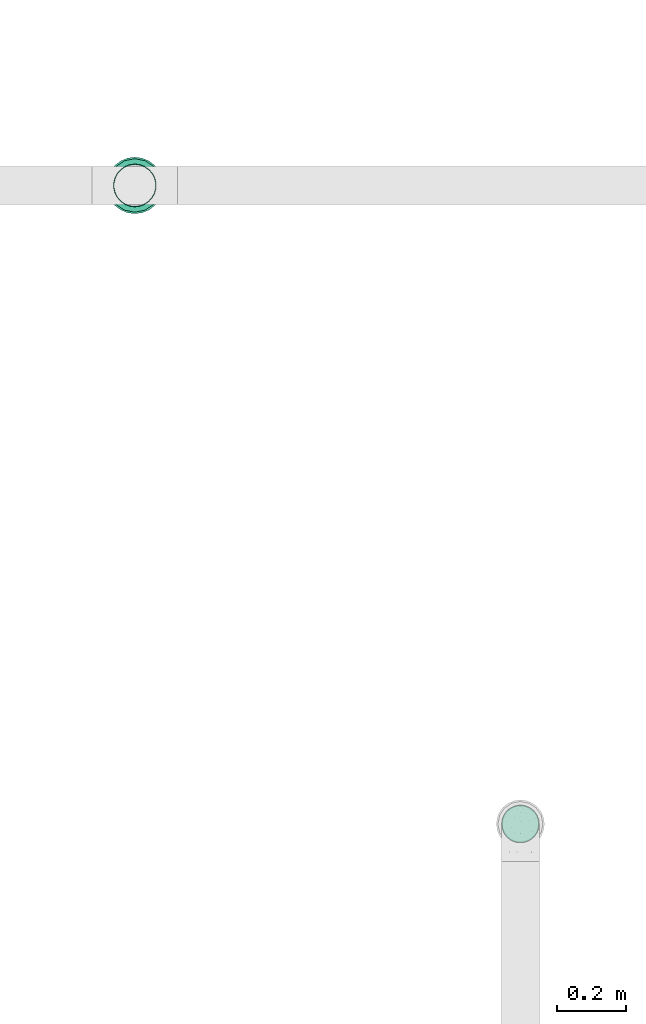
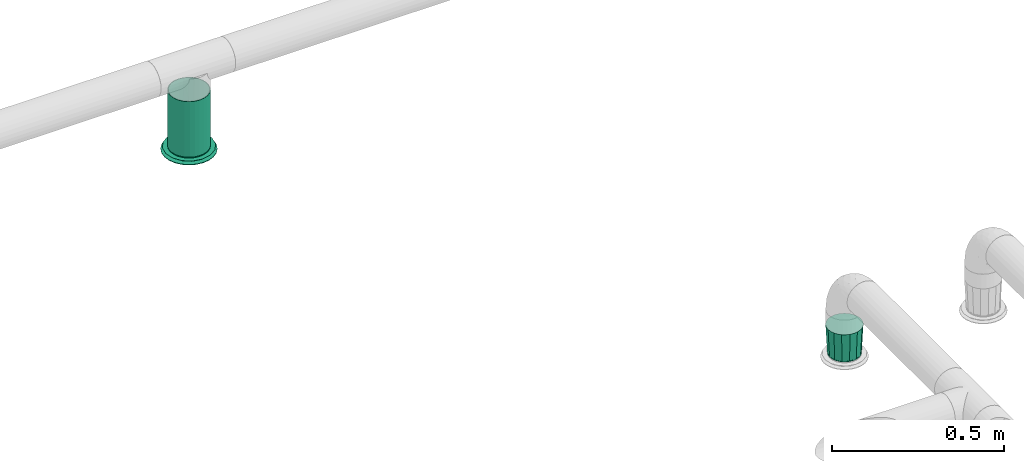
# One storey, part 74 of 115: 1 flow fitting, 1 flow segment, 1 flow terminal.
"""IFC2X3 building model written with IfcOpenShell, lengths in millimetres."""

from ifc_helpers import new_model, entity, si_unit, converted_unit, derived_unit, direction, frame, origin_with_axes, origin_2d_with_axis, place, context, subcontext, project, spatial, hollow_circle, extrude, open_shell, surface_model, source, transform, mapped, material, layer, layer_set, layer_usage, type_object, element, save


model = new_model("IFC2X3")

# Units and contexts
model_context = context("Model", 3, precision=1e-05, world=origin_with_axes(), true_north=direction((0.0, 1.0)))
body_context = subcontext(model_context, "Body", "Model", "MODEL_VIEW")
ifc_project = project(units=[si_unit("AREAUNIT", "SQUARE_METRE"), si_unit("VOLUMEUNIT", "CUBIC_METRE", prefix="DECI"), si_unit("TIMEUNIT", "SECOND"), si_unit("THERMODYNAMICTEMPERATUREUNIT", "DEGREE_CELSIUS"), si_unit("PRESSUREUNIT", "PASCAL"), si_unit("MASSUNIT", "GRAM", prefix="KILO"), si_unit("LENGTHUNIT", "METRE", prefix="MILLI"), si_unit("POWERUNIT", "WATT"), si_unit("ELECTRICCURRENTUNIT", "AMPERE"), si_unit("ELECTRICVOLTAGEUNIT", "VOLT"), derived_unit("VOLUMETRICFLOWRATEUNIT", [(si_unit("VOLUMEUNIT", "CUBIC_METRE", prefix="DECI"), 1), (si_unit("TIMEUNIT", "SECOND"), -1)]), derived_unit("LINEARVELOCITYUNIT", [(si_unit("LENGTHUNIT", "METRE"), 1), (si_unit("TIMEUNIT", "SECOND"), -1)]), derived_unit("MASSDENSITYUNIT", [(si_unit("MASSUNIT", "GRAM", prefix="KILO"), 1), (si_unit("VOLUMEUNIT", "CUBIC_METRE"), -1)]), converted_unit("PLANEANGLEUNIT", "DEGREE", entity("IfcRatioMeasure", 0.01745), si_unit("PLANEANGLEUNIT", "RADIAN"), dimensions=[0, 0, 0, 0, 0, 0, 0])], contexts=[model_context])

# Site, building, storey
site_placement = place(None, origin_with_axes())
site = spatial("IfcSite", under=ifc_project, at=site_placement, CompositionType="ELEMENT")
building_placement = place(site_placement, origin_with_axes())
building = spatial("IfcBuilding", under=site, at=building_placement, Name="mc-building", CompositionType="ELEMENT")
storey_placement = place(building_placement, frame((0.0, 0.0, 2950.0), z_axis=(0.0, 0.0, 1.0), x_axis=(1.0, 0.0, 0.0)))
storey = spatial("IfcBuildingStorey", under=building, at=storey_placement, Name="2. Korrus", CompositionType="ELEMENT", Elevation=2950.0)

# Flow terminal
air_terminal_type = type_object("IfcAirTerminalType", Name="125", PredefinedType="NOTDEFINED")
shared_shape_1 = source(origin_with_axes(), body_context, "Body", "SurfaceModel", [
    surface_model("IfcShellBasedSurfaceModel", [(11.2, 41.25, -71.4471), (11.2, 0.0, -82.5), (11.2, 21.35257, -79.68888), (11.2, 71.4471, -41.25), (11.2, 58.33631, -58.33631), (11.2, 79.68888, -21.35257), (11.2, 82.5, 0.0), (11.2, -79.68888, -21.35257), (11.2, -41.25, -71.4471), (11.2, -21.35257, -79.68888), (11.2, -58.33631, -58.33631), (11.2, -71.4471, -41.25), (11.2, 79.68888, 21.35257), (11.2, 71.4471, 41.25), (11.2, 58.33631, 58.33631), (11.2, 41.25, 71.4471), (11.2, 21.35257, 79.68888), (11.2, -58.33631, 58.33631), (11.2, -21.35257, 79.68888), (11.2, 0.0, 82.5), (11.2, -79.68888, 21.35257), (11.2, -71.4471, 41.25), (11.2, -82.5, 0.0), (11.2, -41.25, 71.4471), (9.2, 21.35257, 79.68888), (9.2, -21.35257, 79.68888), (9.2, 0.0, 82.5), (9.2, 58.33631, 58.33631), (9.2, 41.25, 71.4471), (9.2, 71.4471, 41.25), (9.2, 79.68888, 21.35257), (9.2, -58.33631, 58.33631), (9.2, -41.25, 71.4471), (9.2, -79.68888, 21.35257), (9.2, -71.4471, 41.25), (9.2, -58.33631, -58.33631), (9.2, -82.5, 0.0), (9.2, 79.68888, -21.35257), (9.2, 41.25, -71.4471), (9.2, 71.4471, -41.25), (9.2, -41.25, -71.4471), (9.2, 58.33631, -58.33631), (9.2, 0.0, -82.5), (9.2, 21.35257, -79.68888), (9.2, -71.4471, -41.25), (9.2, -79.68888, -21.35257), (9.2, -21.35257, -79.68888), (9.2, 82.5, 0.0), (9.2, 19.5, 33.77499), (9.2, 0.0, 39.0), (9.2, -19.5, 33.77499), (9.2, -39.0, 0.0), (9.2, 33.77499, 19.5), (9.2, 39.0, 0.0), (9.2, -33.77499, 19.5), (9.2, 0.0, -39.0), (9.2, -33.77499, -19.5), (9.2, -19.5, -33.77499), (9.2, 33.77499, -19.5), (9.2, 19.5, -33.77499), (6.2, 25.24133, 18.3389), (6.2, 31.2, 0.0), (6.2, 9.64133, 29.67296), (6.2, -25.24133, 18.3389), (6.2, -9.64133, 29.67296), (6.2, -31.2, 0.0), (6.2, 25.24133, -18.3389), (6.2, 9.64133, -29.67296), (6.2, -9.64133, -29.67296), (6.2, -25.24133, -18.3389), (9.2, 37.1621, -6.85914), (6.2, 28.22067, -9.16945), (9.2, 35.3242, -13.71829), (6.2, -17.44133, -24.00593), (9.2, -26.6375, -26.6375), (6.2, -28.22067, -9.16945), (9.2, -37.1621, -6.85914), (6.2, 17.44133, -24.00593), (9.2, 9.75, -36.3875), (6.2, 0.0, -29.67296), (9.2, -35.3242, -13.71829), (9.2, 26.6375, -26.6375), (9.2, -9.75, -36.3875), (9.2, -37.1621, 6.85914), (6.2, -28.22067, 9.16945), (9.2, -35.3242, 13.71829), (6.2, 17.44133, 24.00593), (9.2, 26.6375, 26.6375), (6.2, 28.22067, 9.16945), (9.2, 37.1621, 6.85914), (6.2, -17.44133, 24.00593), (9.2, -9.75, 36.3875), (6.2, 0.0, 29.67296), (9.2, 35.3242, 13.71829), (9.2, -26.6375, 26.6375), (9.2, 9.75, 36.3875), (6.2, -26.86438, 64.85634), (6.2, -49.63889, 49.63889), (6.2, -64.85634, 26.86438), (6.2, -70.2, 0.0), (6.2, 64.85634, 26.86438), (6.2, 0.0, 70.2), (6.2, 26.86438, 64.85634), (6.2, 49.63889, 49.63889), (6.2, 70.2, 0.0), (6.2, -64.85634, -26.86438), (6.2, -49.63889, -49.63889), (6.2, -26.86438, -64.85634), (6.2, 26.86438, -64.85634), (6.2, 0.0, -70.2), (6.2, 64.85634, -26.86438), (6.2, 49.63889, -49.63889), (0.0, -29.84931, 72.0626), (0.0, 0.0, 78.0), (0.0, 29.84931, 72.0626), (0.0, 55.15433, 55.15433), (0.0, 78.0, 0.0), (0.0, -55.15433, 55.15433), (0.0, -72.0626, 29.84931), (0.0, -78.0, 0.0), (0.0, 72.0626, 29.84931), (0.0, -72.0626, -29.84931), (0.0, 72.0626, -29.84931), (0.0, 55.15433, -55.15433), (0.0, 29.84931, -72.0626), (0.0, -55.15433, -55.15433), (0.0, -29.84931, -72.0626), (0.0, 0.0, -78.0), (6.2, 66.75025, -17.34304), (0.0, 63.60847, -42.50182), (6.2, 57.24762, -38.25164), (0.0, -14.92465, -75.0313), (6.2, -13.43219, -67.52817), (0.0, 42.50182, -63.60847), (6.2, 38.25164, -57.24762), (0.0, 75.0313, -14.92465), (0.0, 14.92465, -75.0313), (6.2, 13.43219, -67.52817), (0.0, -74.16695, -19.27005), (6.2, -67.52817, -13.43219), (0.0, -42.50182, -63.60847), (6.2, -38.25164, -57.24762), (0.0, -63.60847, -42.50182), (6.2, -57.24762, -38.25164), (6.2, -66.75025, 17.34304), (0.0, -63.60847, 42.50182), (6.2, -57.24762, 38.25164), (0.0, 14.92465, 75.0313), (6.2, 13.43219, 67.52817), (0.0, -42.50182, 63.60847), (6.2, -38.25164, 57.24762), (0.0, -75.0313, 14.92465), (0.0, -14.92465, 75.0313), (6.2, -13.43219, 67.52817), (0.0, 74.16695, 19.27005), (6.2, 67.52817, 13.43219), (0.0, 42.50182, 63.60847), (6.2, 38.25164, 57.24762), (0.0, 63.60847, 42.50182), (6.2, 57.24762, 38.25164), (-3.1, 16.17619, 60.37037), (-3.1, -31.25, 54.12659), (-3.1, 0.0, 62.5), (-3.1, 54.12659, 31.25), (-3.1, 31.25, 54.12659), (-3.1, 44.19417, 44.19417), (-3.1, -54.12659, -31.25), (-3.1, -54.12659, 31.25), (-3.1, -44.19417, 44.19417), (-3.1, -16.17619, 60.37037), (-3.1, -62.5, 0.0), (-3.1, -60.37037, 16.17619), (-3.1, 60.37037, 16.17619), (-3.1, 62.5, 0.0), (-3.1, 60.37037, -16.17619), (-3.1, 54.12659, -31.25), (-3.1, 44.19417, -44.19417), (-3.1, 31.25, -54.12659), (-3.1, 16.17619, -60.37037), (-3.1, -31.25, -54.12659), (-3.1, -44.19417, -44.19417), (-3.1, -60.37037, -16.17619), (-3.1, 0.0, -62.5), (-3.1, -16.17619, -60.37037), (0.0, 31.25, -54.12659), (0.0, -54.12659, -31.25), (0.0, 16.17619, -60.37037), (0.0, 54.12659, -31.25), (0.0, 44.19417, -44.19417), (0.0, 60.37037, -16.17619), (0.0, 62.5, 0.0), (0.0, 54.12659, 31.25), (0.0, 16.17619, 60.37037), (0.0, 0.0, -62.5), (0.0, -31.25, -54.12659), (0.0, -16.17619, -60.37037), (0.0, -44.19417, -44.19417), (0.0, -62.5, 0.0), (0.0, -60.37037, -16.17619), (0.0, 44.19417, 44.19417), (0.0, -54.12659, 31.25), (0.0, 31.25, 54.12659), (0.0, 0.0, 62.5), (0.0, -60.37037, 16.17619), (0.0, -31.25, 54.12659), (0.0, -44.19417, 44.19417), (0.0, -16.17619, 60.37037), (0.0, 60.37037, 16.17619), (-43.1, -14.75269, 55.05777), (-43.1, 0.0, 57.0), (-43.1, 14.75269, 55.05777), (-43.1, 28.5, 49.36345), (-43.1, 40.30508, 40.30508), (-43.1, 49.36345, 28.5), (-43.1, 55.05777, 14.75269), (-43.1, -28.5, 49.36345), (-43.1, -49.36345, 28.5), (-43.1, -40.30508, 40.30508), (-43.1, -57.0, 0.0), (-43.1, -55.05777, 14.75269), (-43.1, -40.30508, -40.30508), (-43.1, 57.0, 0.0), (-43.1, 55.05777, -14.75269), (-43.1, 28.5, -49.36345), (-43.1, 49.36345, -28.5), (-43.1, 14.75269, -55.05777), (-43.1, 40.30508, -40.30508), (-43.1, -49.36345, -28.5), (-43.1, -55.05777, -14.75269), (-43.1, -28.5, -49.36345), (-43.1, 0.0, -57.0), (-43.1, -14.75269, -55.05777), (-3.1, 57.0, 0.0), (-3.1, 14.75269, -55.05777), (-3.1, 28.5, -49.36345), (-3.1, 55.05777, -14.75269), (-3.1, 40.30508, -40.30508), (-3.1, 49.36345, -28.5), (-3.1, 55.05777, 14.75269), (-3.1, -28.5, -49.36345), (-3.1, 0.0, -57.0), (-3.1, -14.75269, -55.05777), (-3.1, -49.36345, -28.5), (-3.1, -57.0, 0.0), (-3.1, -55.05777, -14.75269), (-3.1, -40.30508, -40.30508), (-3.1, -49.36345, 28.5), (-3.1, 49.36345, 28.5), (-3.1, 40.30508, 40.30508), (-3.1, 0.0, 57.0), (-3.1, 28.5, 49.36345), (-3.1, 14.75269, 55.05777), (-3.1, -14.75269, 55.05777), (-3.1, -55.05777, 14.75269), (-3.1, -28.5, 49.36345), (-3.1, -40.30508, 40.30508)], [open_shell([[[0, 1, 2]], [[3, 0, 4]], [[5, 6, 0]], [[5, 0, 3]], [[7, 0, 6]], [[1, 8, 9]], [[1, 0, 8]], [[10, 7, 11]], [[10, 8, 0]], [[7, 10, 0]], [[6, 12, 7]], [[12, 13, 14]], [[12, 14, 15]], [[12, 16, 17]], [[16, 12, 15]], [[18, 16, 19]], [[20, 17, 21]], [[22, 7, 20]], [[17, 18, 23]], [[20, 12, 17]], [[16, 18, 17]], [[20, 7, 12]], [[24, 25, 26]], [[27, 24, 28]], [[27, 29, 30]], [[27, 30, 24]], [[31, 24, 30]], [[25, 31, 32]], [[25, 24, 31]], [[31, 33, 34]], [[31, 30, 33]], [[35, 36, 33]], [[33, 30, 37]], [[33, 37, 35]], [[38, 37, 39]], [[40, 37, 38]], [[38, 39, 41]], [[42, 38, 43]], [[36, 44, 45]], [[35, 44, 36]], [[40, 42, 46]], [[35, 37, 40]], [[38, 42, 40]], [[37, 30, 47]], [[45, 7, 36]], [[44, 11, 45]], [[8, 35, 40]], [[44, 35, 10]], [[9, 40, 46]], [[45, 11, 7]], [[7, 22, 36]], [[9, 8, 40]], [[10, 35, 8]], [[10, 11, 44]], [[1, 9, 46]], [[46, 42, 1]], [[43, 2, 42]], [[38, 0, 43]], [[3, 41, 39]], [[38, 41, 4]], [[5, 39, 37]], [[38, 4, 0]], [[0, 2, 43]], [[6, 5, 37]], [[3, 39, 5]], [[3, 4, 41]], [[47, 6, 37]], [[42, 2, 1]], [[30, 12, 47]], [[29, 13, 30]], [[15, 27, 28]], [[29, 27, 14]], [[16, 28, 24]], [[30, 13, 12]], [[12, 6, 47]], [[16, 15, 28]], [[14, 27, 15]], [[14, 13, 29]], [[19, 16, 24]], [[24, 26, 19]], [[25, 18, 26]], [[32, 23, 25]], [[21, 31, 34]], [[32, 31, 17]], [[20, 34, 33]], [[32, 17, 23]], [[23, 18, 25]], [[36, 22, 20]], [[21, 34, 20]], [[21, 17, 31]], [[33, 36, 20]], [[26, 18, 19]], [[48, 49, 50]], [[50, 51, 52]], [[50, 52, 48]], [[53, 52, 51]], [[50, 54, 51]], [[55, 51, 56]], [[55, 56, 57]], [[58, 55, 59]], [[58, 53, 55]], [[55, 53, 51]], [[60, 61, 62]], [[62, 63, 64]], [[65, 63, 62]], [[62, 61, 65]], [[66, 67, 68]], [[65, 68, 69]], [[65, 61, 68]], [[68, 61, 66]], [[61, 70, 71]], [[58, 71, 72]], [[73, 74, 69]], [[56, 75, 69]], [[76, 51, 65]], [[59, 67, 77]], [[73, 68, 57]], [[74, 73, 57]], [[67, 78, 79]], [[70, 61, 53]], [[65, 75, 76]], [[56, 80, 75]], [[66, 81, 77]], [[82, 57, 68]], [[67, 59, 78]], [[59, 77, 81]], [[81, 66, 58]], [[71, 58, 66]], [[82, 79, 55]], [[78, 55, 79]], [[68, 79, 82]], [[75, 80, 76]], [[56, 69, 74]], [[70, 72, 71]], [[65, 83, 84]], [[54, 84, 85]], [[86, 87, 60]], [[52, 88, 60]], [[89, 53, 61]], [[50, 64, 90]], [[86, 62, 48]], [[87, 86, 48]], [[64, 91, 92]], [[83, 65, 51]], [[61, 88, 89]], [[52, 93, 88]], [[63, 94, 90]], [[95, 48, 62]], [[64, 50, 91]], [[50, 90, 94]], [[94, 63, 54]], [[84, 54, 63]], [[95, 92, 49]], [[91, 49, 92]], [[62, 92, 95]], [[88, 93, 89]], [[52, 60, 87]], [[83, 85, 84]], [[96, 97, 98]], [[98, 99, 96]], [[96, 99, 100]], [[101, 96, 102]], [[100, 103, 102]], [[96, 100, 102]], [[99, 104, 100]], [[105, 106, 107]], [[105, 107, 108]], [[108, 107, 109]], [[110, 104, 111]], [[108, 111, 104]], [[99, 108, 104]], [[108, 99, 105]], [[112, 113, 114]], [[112, 114, 115]], [[116, 112, 115]], [[117, 112, 118]], [[119, 118, 112]], [[119, 112, 116]], [[116, 115, 120]], [[121, 116, 122]], [[123, 124, 122]], [[121, 122, 124]], [[125, 121, 126]], [[126, 121, 124]], [[124, 127, 126]], [[116, 121, 119]], [[110, 122, 128]], [[111, 129, 130]], [[107, 131, 132]], [[108, 133, 134]], [[104, 128, 135]], [[116, 104, 135]], [[111, 134, 123]], [[130, 122, 110]], [[136, 124, 137]], [[128, 122, 135]], [[127, 136, 109]], [[111, 123, 129]], [[119, 138, 139]], [[138, 105, 139]], [[140, 141, 106]], [[124, 108, 137]], [[139, 99, 119]], [[108, 124, 133]], [[106, 125, 140]], [[142, 143, 105]], [[123, 134, 133]], [[131, 127, 132]], [[106, 143, 125]], [[141, 126, 107]], [[126, 141, 140]], [[109, 136, 137]], [[138, 121, 105]], [[122, 130, 129]], [[125, 143, 142]], [[107, 126, 131]], [[127, 109, 132]], [[105, 121, 142]], [[98, 118, 144]], [[97, 145, 146]], [[102, 147, 148]], [[96, 149, 150]], [[99, 144, 151]], [[119, 99, 151]], [[97, 150, 117]], [[146, 118, 98]], [[152, 112, 153]], [[144, 118, 151]], [[113, 152, 101]], [[97, 117, 145]], [[116, 154, 155]], [[154, 100, 155]], [[156, 157, 103]], [[112, 96, 153]], [[155, 104, 116]], [[96, 112, 149]], [[103, 115, 156]], [[158, 159, 100]], [[117, 150, 149]], [[147, 113, 148]], [[103, 159, 115]], [[157, 114, 102]], [[114, 157, 156]], [[101, 152, 153]], [[154, 120, 100]], [[118, 146, 145]], [[115, 159, 158]], [[102, 114, 147]], [[113, 101, 148]], [[100, 120, 158]], [[160, 161, 162]], [[163, 160, 164]], [[161, 160, 163]], [[163, 164, 165]], [[163, 166, 167]], [[161, 167, 168]], [[161, 169, 162]], [[167, 170, 171]], [[167, 161, 163]], [[166, 170, 167]], [[163, 172, 173]], [[173, 174, 175]], [[173, 175, 176]], [[177, 178, 173]], [[177, 173, 176]], [[173, 178, 179]], [[166, 179, 180]], [[181, 170, 166]], [[179, 182, 183]], [[166, 163, 179]], [[182, 179, 178]], [[163, 173, 179]], [[184, 185, 186]], [[187, 184, 188]], [[187, 189, 190]], [[184, 187, 191]], [[192, 185, 184]], [[193, 194, 195]], [[193, 186, 194]], [[194, 185, 196]], [[186, 185, 194]], [[185, 197, 198]], [[190, 191, 187]], [[191, 192, 184]], [[192, 191, 199]], [[192, 200, 185]], [[192, 199, 201]], [[202, 200, 192]], [[197, 200, 203]], [[185, 200, 197]], [[200, 204, 205]], [[202, 204, 200]], [[202, 206, 204]], [[191, 190, 207]], [[172, 207, 173]], [[163, 191, 172]], [[201, 165, 164]], [[163, 165, 199]], [[192, 164, 160]], [[172, 191, 207]], [[207, 190, 173]], [[192, 201, 164]], [[199, 165, 201]], [[199, 191, 163]], [[202, 192, 160]], [[160, 162, 202]], [[169, 206, 162]], [[161, 204, 169]], [[200, 168, 167]], [[161, 168, 205]], [[203, 167, 171]], [[161, 205, 204]], [[204, 206, 169]], [[197, 203, 171]], [[200, 167, 203]], [[200, 205, 168]], [[170, 197, 171]], [[162, 206, 202]], [[181, 198, 170]], [[166, 185, 181]], [[194, 180, 179]], [[166, 180, 196]], [[195, 179, 183]], [[181, 185, 198]], [[198, 197, 170]], [[195, 194, 179]], [[196, 180, 194]], [[196, 185, 166]], [[193, 195, 183]], [[183, 182, 193]], [[178, 186, 182]], [[177, 184, 178]], [[187, 176, 175]], [[177, 176, 188]], [[189, 175, 174]], [[177, 188, 184]], [[184, 186, 178]], [[190, 189, 174]], [[187, 175, 189]], [[187, 188, 176]], [[173, 190, 174]], [[182, 186, 193]], [[208, 209, 210]], [[211, 208, 210]], [[212, 213, 214]], [[212, 214, 211]], [[208, 211, 214]], [[215, 216, 217]], [[216, 215, 208]], [[216, 218, 219]], [[216, 208, 214]], [[216, 220, 218]], [[216, 214, 221]], [[220, 216, 222]], [[223, 222, 224]], [[223, 225, 222]], [[223, 224, 226]], [[220, 222, 225]], [[218, 227, 228]], [[220, 227, 218]], [[229, 230, 231]], [[229, 220, 225]], [[230, 229, 225]], [[216, 221, 222]], [[232, 233, 234]], [[235, 234, 236]], [[235, 232, 234]], [[235, 236, 237]], [[238, 239, 233]], [[240, 239, 241]], [[240, 233, 239]], [[242, 243, 244]], [[245, 239, 246]], [[242, 245, 243]], [[238, 233, 232]], [[238, 247, 248]], [[238, 248, 249]], [[250, 251, 249]], [[250, 249, 248]], [[238, 249, 252]], [[243, 246, 253]], [[245, 246, 243]], [[246, 254, 255]], [[254, 246, 252]], [[238, 252, 246]], [[246, 239, 238]], [[214, 238, 221]], [[213, 247, 214]], [[250, 212, 211]], [[213, 212, 248]], [[251, 211, 210]], [[214, 247, 238]], [[238, 232, 221]], [[251, 250, 211]], [[248, 212, 250]], [[248, 247, 213]], [[249, 251, 210]], [[210, 209, 249]], [[254, 215, 217]], [[246, 216, 219]], [[217, 216, 255]], [[253, 219, 218]], [[208, 254, 252]], [[208, 215, 254]], [[252, 249, 208]], [[217, 255, 254]], [[216, 246, 255]], [[253, 246, 219]], [[218, 243, 253]], [[208, 249, 209]], [[228, 244, 218]], [[227, 242, 228]], [[239, 220, 229]], [[227, 220, 245]], [[241, 229, 231]], [[228, 242, 244]], [[244, 243, 218]], [[241, 239, 229]], [[245, 220, 239]], [[245, 242, 227]], [[240, 241, 231]], [[231, 230, 240]], [[233, 230, 225]], [[234, 225, 223]], [[237, 224, 222]], [[221, 235, 222]], [[225, 234, 233]], [[234, 223, 226]], [[234, 226, 236]], [[226, 224, 236]], [[224, 237, 236]], [[235, 237, 222]], [[221, 232, 235]], [[230, 233, 240]]])]),
])
flow_terminal_placement = place(storey_placement, frame((28929.65714, 6254.72535, 2200.0), z_axis=(1.0, 0.0, 0.0), x_axis=(0.0, 0.0, -1.0)))
element("IfcFlowTerminal", 1, at=flow_terminal_placement, inside=storey, type_object=air_terminal_type, Name="125", context=body_context, shape_type="MappedRepresentation", body=[
    mapped(shared_shape_1, transform((0.0, 0.0, 0.0), scale=1.0)),
])

# Flow fitting
duct_fitting_type = type_object("IfcDuctFittingType", PredefinedType="TRANSITION")
shared_shape_2 = source(origin_with_axes(), body_context, "Body", "SurfaceModel", [
    surface_model("IfcShellBasedSurfaceModel", [(100.0, -55.0, 0.0), (100.0, -12.23865, 53.62104), (100.0, -34.29194, 43.00073), (100.0, 49.55329, 23.86361), (100.0, 34.29194, 43.00073), (100.0, 49.55329, -23.86361), (0.0, -45.04844, -21.69419), (0.0, -50.0, 0.0), (0.0, -45.04844, 21.69419), (0.0, 31.17449, 39.09157), (0.0, 45.04844, 21.69419), (0.0, 50.0, 0.0), (98.0, 47.63139, 27.5), (98.0, 0.0, 55.0), (98.0, 38.89087, 38.89087), (98.0, -38.89087, 38.89087), (98.0, -47.63139, 27.5), (100.0, 12.23865, 53.62104), (100.0, -49.55329, 23.86361), (100.0, 55.0, 0.0), (100.0, 12.23865, -53.62104), (100.0, 34.29194, -43.00073), (100.0, -49.55329, -23.86361), (100.0, -34.29194, -43.00073), (100.0, -12.23865, -53.62104), (0.0, -31.17449, 39.09157), (0.0, -11.12605, 48.7464), (0.0, 11.12605, 48.7464), (0.0, -31.17449, -39.09157), (0.0, 11.12605, -48.7464), (0.0, -11.12605, -48.7464), (0.0, 45.04844, -21.69419), (0.0, 31.17449, -39.09157), (0.0, 47.52422, -10.84709), (0.0, 38.11147, -30.39288), (100.0, 41.92261, -33.43217), (100.0, -41.92261, -33.43217), (0.0, -38.11147, -30.39288), (100.0, 23.2653, -48.31088), (0.0, 21.15027, -43.91899), (100.0, 52.32388, -11.72483), (0.0, 0.0, -48.7464), (100.0, 0.0, -53.62104), (0.0, -21.15027, -43.91899), (100.0, -23.2653, -48.31088), (0.0, -47.52422, -10.84709), (100.0, -52.32388, -11.72483), (0.0, -47.52422, 10.84709), (0.0, -38.11147, 30.39288), (100.0, -41.92261, 33.43217), (100.0, 41.92261, 33.43217), (0.0, 38.11147, 30.39288), (100.0, -23.2653, 48.31088), (0.0, -21.15027, 43.91899), (100.0, -52.32388, 11.72483), (0.0, 0.0, 48.7464), (100.0, 0.0, 53.62104), (0.0, 21.15027, 43.91899), (100.0, 23.2653, 48.31088), (0.0, 47.52422, 10.84709), (100.0, 52.32388, 11.72483), (100.0, -14.23505, -53.12592), (100.0, 0.0, -55.0), (100.0, -27.5, -47.63139), (100.0, 27.5, -47.63139), (100.0, -38.89087, -38.89087), (100.0, -53.12592, -14.23505), (100.0, -47.63139, -27.5), (100.0, -47.63139, 27.5), (100.0, 14.23505, -53.12592), (100.0, 38.89087, -38.89087), (100.0, 47.63139, -27.5), (100.0, 47.63139, 27.5), (100.0, 53.12592, -14.23505), (100.0, -53.12592, 14.23505), (100.0, -38.89087, 38.89087), (100.0, -27.5, 47.63139), (100.0, 0.0, 55.0), (100.0, -14.23505, 53.12592), (100.0, 53.12592, 14.23505), (100.0, 38.89087, 38.89087), (100.0, 27.5, 47.63139), (100.0, 14.23505, 53.12592), (98.0, -27.5, 47.63139), (98.0, -14.23505, 53.12592), (98.0, -53.12592, -14.23505), (98.0, 14.23505, 53.12592), (98.0, 27.5, 47.63139), (98.0, 53.12592, 14.23505), (98.0, 55.0, 0.0), (98.0, -47.63139, -27.5), (98.0, -53.12592, 14.23505), (98.0, 27.5, -47.63139), (98.0, -27.5, -47.63139), (98.0, -38.89087, -38.89087), (98.0, 0.0, -55.0), (98.0, -14.23505, -53.12592), (98.0, 38.89087, -38.89087), (98.0, 47.63139, -27.5), (98.0, 53.12592, -14.23505), (98.0, 14.23505, -53.12592), (98.0, -55.0, 0.0), (0.0, 0.0, 50.0), (0.0, 35.35534, 35.35534), (0.0, -12.94095, 48.29629), (0.0, -25.0, 43.30127), (0.0, -35.35534, 35.35534), (0.0, -48.29629, 12.94095), (0.0, -43.30127, 25.0), (0.0, 25.0, 43.30127), (0.0, 12.94095, 48.29629), (0.0, 43.30127, 25.0), (0.0, 48.29629, 12.94095), (0.0, 25.0, -43.30127), (0.0, 48.29629, -12.94095), (0.0, -48.29629, -12.94095), (0.0, -43.30127, -25.0), (0.0, -12.94095, -48.29629), (0.0, -25.0, -43.30127), (0.0, -35.35534, -35.35534), (0.0, 43.30127, -25.0), (0.0, 35.35534, -35.35534), (0.0, 12.94095, -48.29629), (0.0, 0.0, -50.0), (2.0, -35.35534, -35.35534), (2.0, -25.0, -43.30127), (2.0, -12.94095, -48.29629), (2.0, -43.30127, -25.0), (2.0, 0.0, -50.0), (2.0, -48.29629, -12.94095), (2.0, -50.0, 0.0), (2.0, 12.94095, -48.29629), (2.0, 25.0, -43.30127), (2.0, 43.30127, -25.0), (2.0, 48.29629, -12.94095), (2.0, 35.35534, -35.35534), (2.0, -48.29629, 12.94095), (2.0, -35.35534, 35.35534), (2.0, -43.30127, 25.0), (2.0, 35.35534, 35.35534), (2.0, -12.94095, 48.29629), (2.0, -25.0, 43.30127), (2.0, 0.0, 50.0), (2.0, 43.30127, 25.0), (2.0, 48.29629, 12.94095), (2.0, 50.0, 0.0), (2.0, 25.0, 43.30127), (2.0, 12.94095, 48.29629)], [open_shell([[[0, 1, 2]], [[3, 4, 5]], [[6, 7, 8]], [[9, 10, 11]], [[12, 13, 14]], [[15, 13, 16]], [[0, 4, 17]], [[2, 18, 0]], [[1, 0, 17]], [[3, 5, 19]], [[20, 21, 5]], [[22, 20, 5]], [[22, 5, 0]], [[22, 23, 24]], [[22, 24, 20]], [[4, 0, 5]], [[8, 25, 6]], [[6, 25, 26]], [[6, 26, 27]], [[11, 27, 9]], [[28, 6, 29]], [[30, 28, 29]], [[31, 6, 11]], [[31, 32, 29]], [[31, 29, 6]], [[27, 11, 6]], [[31, 33, 5]], [[34, 35, 32]], [[36, 22, 6]], [[36, 37, 23]], [[38, 29, 39]], [[33, 40, 5]], [[33, 11, 40]], [[19, 40, 11]], [[32, 21, 39]], [[32, 35, 21]], [[34, 31, 35]], [[30, 41, 42]], [[28, 43, 44]], [[42, 41, 20]], [[7, 45, 46]], [[38, 39, 21]], [[46, 0, 7]], [[6, 37, 36]], [[38, 20, 29]], [[43, 30, 24]], [[42, 24, 30]], [[28, 23, 37]], [[6, 22, 45]], [[35, 31, 5]], [[44, 43, 24]], [[20, 41, 29]], [[46, 45, 22]], [[44, 23, 28]], [[8, 47, 18]], [[48, 49, 25]], [[50, 3, 10]], [[50, 51, 4]], [[52, 26, 53]], [[47, 54, 18]], [[47, 7, 54]], [[0, 54, 7]], [[25, 2, 53]], [[25, 49, 2]], [[48, 8, 49]], [[27, 55, 56]], [[9, 57, 58]], [[56, 55, 1]], [[11, 59, 60]], [[52, 53, 2]], [[60, 19, 11]], [[10, 51, 50]], [[52, 1, 26]], [[57, 27, 17]], [[56, 17, 27]], [[9, 4, 51]], [[10, 3, 59]], [[49, 8, 18]], [[58, 57, 17]], [[1, 55, 26]], [[60, 59, 3]], [[58, 4, 9]], [[61, 62, 63]], [[63, 64, 65]], [[66, 67, 68]], [[65, 64, 67]], [[67, 64, 68]], [[69, 64, 62]], [[64, 63, 62]], [[70, 71, 64]], [[72, 64, 71]], [[71, 73, 19]], [[74, 0, 66]], [[72, 68, 64]], [[75, 68, 76]], [[77, 78, 76]], [[72, 76, 68]], [[76, 72, 77]], [[79, 72, 19]], [[19, 72, 71]], [[80, 81, 77]], [[77, 72, 80]], [[82, 77, 81]], [[74, 66, 68]], [[83, 84, 13]], [[15, 83, 13]], [[12, 16, 13]], [[16, 12, 85]], [[86, 87, 13]], [[87, 14, 13]], [[88, 89, 12]], [[89, 90, 12]], [[91, 16, 85]], [[90, 85, 12]], [[89, 92, 90]], [[93, 94, 95]], [[95, 94, 90]], [[96, 93, 95]], [[97, 92, 98]], [[98, 89, 99]], [[100, 95, 92]], [[92, 89, 98]], [[90, 92, 95]], [[101, 91, 85]], [[89, 73, 99]], [[99, 71, 98]], [[92, 97, 64]], [[70, 97, 98]], [[100, 92, 69]], [[73, 71, 99]], [[89, 19, 73]], [[92, 64, 69]], [[64, 97, 70]], [[98, 71, 70]], [[100, 69, 62]], [[62, 95, 100]], [[95, 61, 96]], [[96, 63, 93]], [[90, 94, 67]], [[65, 94, 93]], [[85, 90, 66]], [[63, 65, 93]], [[96, 61, 63]], [[85, 66, 0]], [[66, 90, 67]], [[94, 65, 67]], [[85, 0, 101]], [[62, 61, 95]], [[101, 74, 91]], [[91, 68, 16]], [[83, 15, 76]], [[75, 15, 16]], [[84, 83, 78]], [[74, 68, 91]], [[101, 0, 74]], [[83, 76, 78]], [[76, 15, 75]], [[16, 68, 75]], [[84, 78, 77]], [[77, 13, 84]], [[13, 82, 86]], [[86, 81, 87]], [[12, 14, 72]], [[80, 14, 87]], [[88, 12, 79]], [[81, 80, 87]], [[86, 82, 81]], [[88, 79, 19]], [[79, 12, 72]], [[14, 80, 72]], [[88, 19, 89]], [[77, 82, 13]], [[102, 103, 104]], [[105, 104, 106]], [[107, 108, 106]], [[103, 106, 104]], [[106, 103, 107]], [[109, 103, 110]], [[103, 102, 110]], [[111, 112, 103]], [[113, 103, 112]], [[112, 11, 114]], [[107, 103, 113]], [[113, 115, 107]], [[116, 115, 117]], [[117, 118, 119]], [[116, 117, 119]], [[117, 115, 113]], [[120, 121, 114]], [[113, 114, 121]], [[113, 122, 117]], [[113, 112, 114]], [[117, 122, 123]], [[7, 107, 115]], [[124, 125, 126]], [[127, 124, 126]], [[128, 129, 126]], [[127, 126, 129]], [[130, 129, 128]], [[131, 132, 128]], [[132, 130, 128]], [[133, 134, 135]], [[132, 135, 134]], [[132, 134, 130]], [[134, 136, 130]], [[137, 138, 136]], [[137, 136, 139]], [[140, 137, 139]], [[141, 137, 140]], [[142, 140, 139]], [[143, 139, 144]], [[144, 134, 145]], [[146, 147, 139]], [[139, 136, 144]], [[139, 147, 142]], [[136, 134, 144]], [[11, 134, 114]], [[114, 133, 120]], [[113, 121, 132]], [[135, 121, 120]], [[122, 113, 131]], [[134, 133, 114]], [[11, 145, 134]], [[113, 132, 131]], [[132, 121, 135]], [[120, 133, 135]], [[122, 131, 128]], [[128, 123, 122]], [[123, 126, 117]], [[117, 125, 118]], [[116, 119, 127]], [[124, 119, 118]], [[115, 116, 129]], [[125, 124, 118]], [[117, 126, 125]], [[115, 129, 130]], [[129, 116, 127]], [[119, 124, 127]], [[115, 130, 7]], [[128, 126, 123]], [[7, 136, 107]], [[107, 138, 108]], [[105, 106, 141]], [[137, 106, 108]], [[104, 105, 140]], [[136, 138, 107]], [[7, 130, 136]], [[105, 141, 140]], [[141, 106, 137]], [[108, 138, 137]], [[104, 140, 142]], [[142, 102, 104]], [[102, 147, 110]], [[110, 146, 109]], [[111, 103, 143]], [[139, 103, 109]], [[112, 111, 144]], [[146, 139, 109]], [[110, 147, 146]], [[112, 144, 145]], [[144, 111, 143]], [[103, 139, 143]], [[112, 145, 11]], [[142, 147, 102]]])]),
])
flow_fitting_placement = place(storey_placement, frame((30053.28275, 4393.85998, 2203.1), z_axis=(0.0, -1.0, 0.0), x_axis=(0.0, 0.0, 1.0)))
element("IfcFlowFitting", 2, at=flow_fitting_placement, inside=storey, type_object=duct_fitting_type, context=body_context, shape_type="MappedRepresentation", body=[
    mapped(shared_shape_2, transform((0.0, 0.0, 0.0), scale=1.0)),
])

# Flow segment
ifc_material = material(Name="FZ1")
ifc_layer = layer(ifc_material, 0.0)
ifc_layer_set = layer_set([ifc_layer], Name="FZ1")
ifc_layer_usage = layer_usage(ifc_layer_set, "AXIS1", "POSITIVE", 0.0)
duct_segment_type = type_object("IfcDuctSegmentType", PredefinedType="RIGIDSEGMENT")
shared_shape_3 = source(origin_with_axes(), body_context, "Body", "SweptSolid", [
    extrude(hollow_circle(Radius=62.5, WallThickness=2.0, at=origin_2d_with_axis()), frame((0.0, 0.0, 0.0), z_axis=(1.0, 0.0, 0.0), x_axis=(0.0, 1.0, 0.0)), (0.0, 0.0, 1.0), 196.9),
])
flow_segment_placement = place(storey_placement, frame((28929.65714, 6254.72535, 2400.0), z_axis=(-1.0, 0.0, 0.0), x_axis=(0.0, 0.0, -1.0)))
element("IfcFlowSegment", 3, at=flow_segment_placement, inside=storey, type_object=duct_segment_type, material=ifc_layer_usage, context=body_context, shape_type="MappedRepresentation", body=[
    mapped(shared_shape_3, transform((0.0, 0.0, 0.0), scale=1.0)),
])

save(model, "model.ifc")
